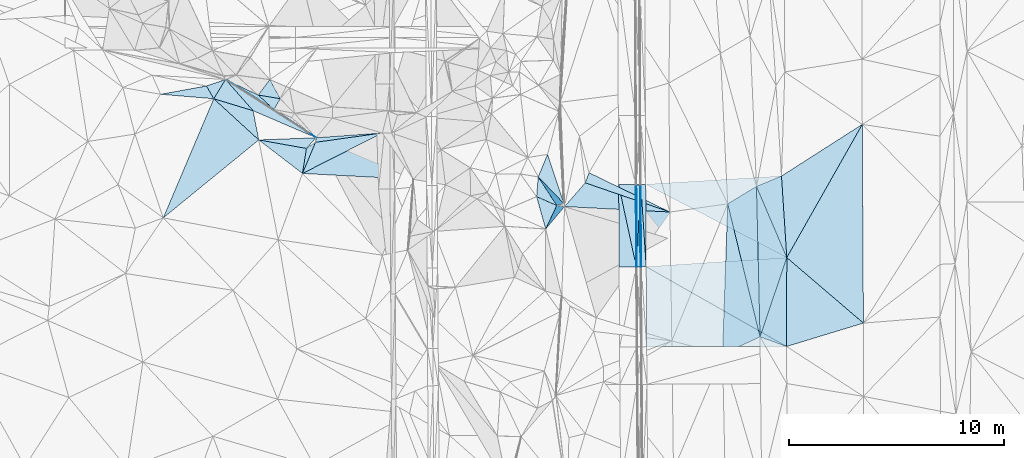
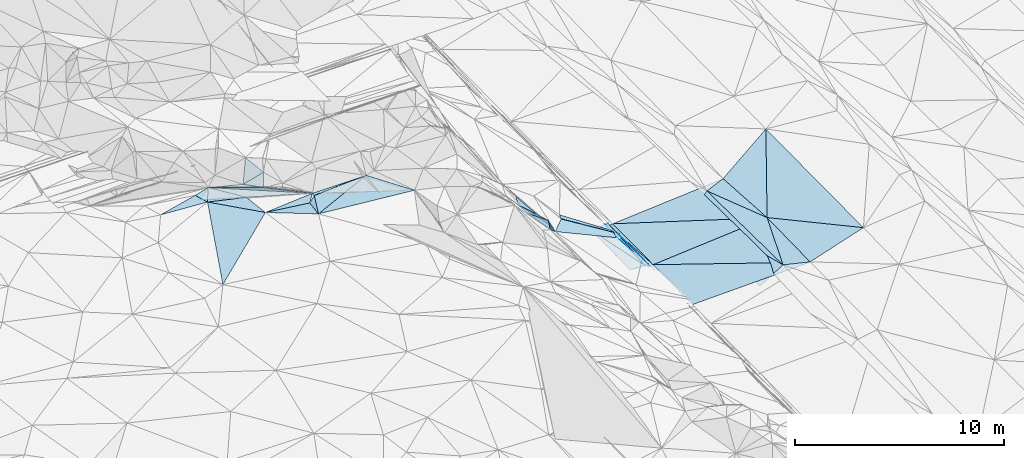
# One storey, part 56 of 275: 45 plates.
"""IFC2X3 building model written with IfcOpenShell, lengths in millimetres."""

from ifc_helpers import new_model, si_unit, frame, origin_with_axes, place, context, subcontext, project, spatial, polyline, outline, extrude, material, type_object, element, save


model = new_model("IFC2X3")

# Units and contexts
model_context = context("Model", 3, precision=1e-05, world=origin_with_axes())
body_context = subcontext(model_context, "Body", "Model", "MODEL_VIEW")
ifc_project = project(units=[si_unit("LENGTHUNIT", "METRE", prefix="MILLI"), si_unit("AREAUNIT", "SQUARE_METRE"), si_unit("VOLUMEUNIT", "CUBIC_METRE"), si_unit("MASSUNIT", "GRAM", prefix="KILO"), si_unit("TIMEUNIT", "SECOND"), si_unit("PLANEANGLEUNIT", "RADIAN"), si_unit("SOLIDANGLEUNIT", "STERADIAN"), si_unit("THERMODYNAMICTEMPERATUREUNIT", "DEGREE_CELSIUS"), si_unit("LUMINOUSINTENSITYUNIT", "LUMEN")], contexts=[model_context])

# Site, building, storey
site_placement = place(None, origin_with_axes())
site = spatial("IfcSite", under=ifc_project, at=site_placement, CompositionType="ELEMENT")
building_placement = place(site_placement, origin_with_axes())
building = spatial("IfcBuilding", under=site, at=building_placement, Name="Undefined", CompositionType="ELEMENT")
storey_placement = place(building_placement, origin_with_axes())
storey = spatial("IfcBuildingStorey", under=building, at=storey_placement, Name="Undefined", CompositionType="ELEMENT", Elevation=0.0)

# Plates
ifc_material = material()
plate_type_1 = type_object("IfcPlateType", PredefinedType="NOTDEFINED")
plate_1_placement = place(storey_placement, frame((-94049.4691106882, 47124.3842748434, 42016.0087509356), z_axis=(-0.970150804761025, -0.000843614877214956, -0.242500936772365), x_axis=(-0.00564236911128292, 0.999801756931878, 0.0190947769492665)))
element("IfcPlate", 1, at=plate_1_placement, inside=storey, type_object=plate_type_1, material=ifc_material, Name="00_PR", context=body_context, shape_type="SweptSolid", body=[
    extrude(outline(polyline([(0.0, 0.0), (3822.14477539063, -4.42378222942352e-09), (-1.945427775383, 123.677734375), (0.0, 0.0)])), frame((-8.85201319254618e-08, 2.18876761149539e-07, -0.5000001331573), z_axis=(0.0, 0.0, 1.0), x_axis=(1.0, 0.0, 0.0)), (0.0, 0.0, 1.0), 1.0),
])
plate_2_placement = place(storey_placement, frame((-94071.0352614292, 50945.7712675142, 42088.9925319801), z_axis=(-0.970540368074091, -0.000927874544757817, -0.240936782138878), x_axis=(0.240846376074367, 0.0239246409937553, -0.970268331280149)))
element("IfcPlate", 2, at=plate_2_placement, inside=storey, type_object=plate_type_1, material=ifc_material, Name="00_PR", context=body_context, shape_type="SweptSolid", body=[
    extrude(outline(polyline([(0.0, 0.0), (123.677124023438, -3.20142135024071e-10), (108.250579833984, 3824.55786132813), (0.0, 0.0)])), frame((-8.85201319254618e-08, 2.18876761149539e-07, -0.5000001331573), z_axis=(0.0, 0.0, 1.0), x_axis=(1.0, 0.0, 0.0)), (0.0, 0.0, 1.0), 1.0),
])
plate_type_2 = type_object("IfcPlateType", PredefinedType="NOTDEFINED")
plate_3_placement = place(storey_placement, frame((-94248.9903613323, 47123.2021820058, 42016.2301910769), z_axis=(-0.0201054512316629, 0.0189772573786107, -0.999617744206833), x_axis=(0.00220621589437379, 0.999818250675828, 0.0189366899682804)))
element("IfcPlate", 3, at=plate_3_placement, inside=storey, type_object=plate_type_2, material=ifc_material, Name="00_PR", context=body_context, shape_type="SweptSolid", body=[
    extrude(outline(polyline([(0.0, 0.0), (3822.3681640625, 5.355104804039e-09), (0.233179047703743, 30.0052471160889), (0.0, 0.0)])), frame((-8.85201319254618e-08, 2.18876761149539e-07, -0.5000001331573), z_axis=(0.0, 0.0, 1.0), x_axis=(1.0, 0.0, 0.0)), (0.0, 0.0, 1.0), 1.0),
])
plate_4_placement = place(storey_placement, frame((-94240.557385882, 50944.8755416985, 42088.6131918384), z_axis=(-0.0200937306992906, 0.0189772347856129, -0.999617980303714), x_axis=(-0.00220621588740689, -0.999818250676177, -0.0189366899506442)))
element("IfcPlate", 4, at=plate_4_placement, inside=storey, type_object=plate_type_2, material=ifc_material, Name="00_PR", context=body_context, shape_type="SweptSolid", body=[
    extrude(outline(polyline([(0.0, 0.0), (3822.3681640625, 5.355104804039e-09), (0.214805215597153, 30.0057525634766), (0.0, 0.0)])), frame((-8.85201319254618e-08, 2.18876761149539e-07, -0.5000001331573), z_axis=(0.0, 0.0, 1.0), x_axis=(1.0, 0.0, 0.0)), (0.0, 0.0, 1.0), 1.0),
])
plate_type_3 = type_object("IfcPlateType", PredefinedType="NOTDEFINED")
plate_5_placement = place(storey_placement, frame((-94248.9903613323, 47123.2021820058, 42016.2301910769), z_axis=(-0.0201058379220584, 0.0189746238774516, -0.999617786421471), x_axis=(-0.99978229263716, -0.00596045911850218, 0.0199960060082088)))
element("IfcPlate", 5, at=plate_5_placement, inside=storey, type_object=plate_type_3, material=ifc_material, Name="00_PR", context=body_context, shape_type="SweptSolid", body=[
    extrude(outline(polyline([(0.0, 0.0), (800.159790039063, 5.60248736292124e-09), (800.403381347656, 3822.779296875), (0.0, 0.0)])), frame((-8.85201319254618e-08, 2.18876761149539e-07, -0.5000001331573), z_axis=(0.0, 0.0, 1.0), x_axis=(1.0, 0.0, 0.0)), (0.0, 0.0, 1.0), 1.0),
])
plate_6_placement = place(storey_placement, frame((-95070.5458396395, 50940.4544931018, 42105.2131907828), z_axis=(-0.0200937306992906, 0.0189772347856129, -0.999617980303714), x_axis=(0.999785877876545, 0.0053252250960376, -0.0199960090093601)))
element("IfcPlate", 6, at=plate_6_placement, inside=storey, type_object=plate_type_3, material=ifc_material, Name="00_PR", context=body_context, shape_type="SweptSolid", body=[
    extrude(outline(polyline([(0.0, 0.0), (800.15966796875, 1.0113581083715e-09), (802.831176757813, 3822.27001953125), (0.0, 0.0)])), frame((-8.85201319254618e-08, 2.18876761149539e-07, -0.5000001331573), z_axis=(0.0, 0.0, 1.0), x_axis=(1.0, 0.0, 0.0)), (0.0, 0.0, 1.0), 1.0),
])
plate_type_4 = type_object("IfcPlateType", PredefinedType="NOTDEFINED")
plate_7_placement = place(storey_placement, frame((-94040.7465511964, 50948.7402933009, 41968.613357986), z_axis=(0.032498795467164, 0.0192577897591659, -0.999286228178281), x_axis=(0.0657092031432121, -0.997692452506924, -0.017090079958929)))
element("IfcPlate", 7, at=plate_7_placement, inside=storey, type_object=plate_type_4, material=ifc_material, Name="00_PR", context=body_context, shape_type="SweptSolid", body=[
    extrude(outline(polyline([(0.0, 0.0), (3831.63793945313, -3.01224645227194e-09), (3817.68505859375, 229.701293945313), (0.0, 0.0)])), frame((-8.85201319254618e-08, 2.18876761149539e-07, -0.5000001331573), z_axis=(0.0, 0.0, 1.0), x_axis=(1.0, 0.0, 0.0)), (0.0, 0.0, 1.0), 1.0),
])
plate_8_placement = place(storey_placement, frame((-94040.7469434197, 50948.7402655422, 41968.6133447093), z_axis=(0.0317146564647974, 0.0192065938860988, -0.999312407266424), x_axis=(0.998439383511723, 0.0453729910903855, 0.0325590100009581)))
element("IfcPlate", 8, at=plate_8_placement, inside=storey, type_object=plate_type_4, material=ifc_material, Name="00_PR", context=body_context, shape_type="SweptSolid", body=[
    extrude(outline(polyline([(0.0, 0.0), (230.504547119141, -9.45874489843845e-10), (75.7971954345703, 3830.88818359375), (0.0, 0.0)])), frame((-8.85201319254618e-08, 2.18876761149539e-07, -0.5000001331573), z_axis=(0.0, 0.0, 1.0), x_axis=(1.0, 0.0, 0.0)), (0.0, 0.0, 1.0), 1.0),
])
plate_type_5 = type_object("IfcPlateType", PredefinedType="NOTDEFINED")
plate_9_placement = place(storey_placement, frame((-98813.8662279933, 51306.4371091306, 44619.7632845197), z_axis=(-0.796210365658024, -0.376725235412677, -0.473420690952539), x_axis=(0.596366558088793, -0.620550605791343, -0.509179608827105)))
element("IfcPlate", 9, at=plate_9_placement, inside=storey, type_object=plate_type_5, material=ifc_material, Name="00", context=body_context, shape_type="SweptSolid", body=[
    extrude(outline(polyline([(0.0, 0.0), (2003.22241210938, -5.07861841470003e-09), (1541.86572265625, 549.681762695313), (0.0, 0.0)])), frame((-8.85201319254618e-08, 2.18876761149539e-07, -0.5000001331573), z_axis=(0.0, 0.0, 1.0), x_axis=(1.0, 0.0, 0.0)), (0.0, 0.0, 1.0), 1.0),
])
plate_type_6 = type_object("IfcPlateType", PredefinedType="NOTDEFINED")
plate_10_placement = place(storey_placement, frame((-94070.550046915, 50945.7812789745, 42088.6130915249), z_axis=(-0.00011385145127799, 0.019094438500524, -0.999817678107462), x_axis=(0.00564236912621122, -0.999801756931813, -0.0190947769482348)))
element("IfcPlate", 10, at=plate_10_placement, inside=storey, type_object=plate_type_6, material=ifc_material, Name="00_PR", context=body_context, shape_type="SweptSolid", body=[
    extrude(outline(polyline([(0.0, 0.0), (3822.14477539063, -4.42378222942352e-09), (3822.19897460938, 169.999664306641), (0.0, 0.0)])), frame((-8.85201319254618e-08, 2.18876761149539e-07, -0.5000001331573), z_axis=(0.0, 0.0, 1.0), x_axis=(1.0, 0.0, 0.0)), (0.0, 0.0, 1.0), 1.0),
])
plate_11_placement = place(storey_placement, frame((-94218.980736597, 47123.3806295609, 42015.6300917683), z_axis=(-0.000101724851935278, 0.0190939669352112, -0.99981768842061), x_axis=(-0.00564236911128292, 0.999801756931878, 0.0190947769492665)))
element("IfcPlate", 11, at=plate_11_placement, inside=storey, type_object=plate_type_6, material=ifc_material, Name="00_PR", context=body_context, shape_type="SweptSolid", body=[
    extrude(outline(polyline([(0.0, 0.0), (3822.25268554688, -1.35623849928379e-08), (3822.19897460938, 169.999755859375), (0.0, 0.0)])), frame((-8.85201319254618e-08, 2.18876761149539e-07, -0.5000001331573), z_axis=(0.0, 0.0, 1.0), x_axis=(1.0, 0.0, 0.0)), (0.0, 0.0, 1.0), 1.0),
])
plate_type_7 = type_object("IfcPlateType", PredefinedType="NOTDEFINED")
plate_12_placement = place(storey_placement, frame((-87491.6404198955, 51343.7037610381, 42163.2043052389), z_axis=(0.0283562339703342, 0.0202607606559367, -0.999392528275383), x_axis=(0.0645135621093858, -0.997747239133415, -0.0183969319617568)))
element("IfcPlate", 12, at=plate_12_placement, inside=storey, type_object=plate_type_7, material=ifc_material, Name="00_PR", context=body_context, shape_type="SweptSolid", body=[
    extrude(outline(polyline([(0.0, 0.0), (3803.40576171875, 1.20489858090878e-08), (-20.5789337158203, 6333.38134765625), (0.0, 0.0)])), frame((-8.85201319254618e-08, 2.18876761149539e-07, -0.5000001331573), z_axis=(0.0, 0.0, 1.0), x_axis=(1.0, 0.0, 0.0)), (0.0, 0.0, 1.0), 1.0),
])
plate_type_8 = type_object("IfcPlateType", PredefinedType="NOTDEFINED")
plate_13_placement = place(storey_placement, frame((-87246.2694836148, 47548.8661966718, 42093.2332986369), z_axis=(0.027715106074778, 0.0204726739549851, -0.999406194955983), x_axis=(-0.0019628878972951, -0.999787209570796, -0.0205349129470802)))
element("IfcPlate", 13, at=plate_13_placement, inside=storey, type_object=plate_type_8, material=ifc_material, Name="00_PR", context=body_context, shape_type="SweptSolid", body=[
    extrude(outline(polyline([(0.0, 0.0), (4137.392578125, 6.63567334413528e-09), (439.577911376953, 6544.369140625), (0.0, 0.0)])), frame((-8.85201319254618e-08, 2.18876761149539e-07, -0.5000001331573), z_axis=(0.0, 0.0, 1.0), x_axis=(1.0, 0.0, 0.0)), (0.0, 0.0, 1.0), 1.0),
])
plate_type_9 = type_object("IfcPlateType", PredefinedType="NOTDEFINED")
plate_14_placement = place(storey_placement, frame((-93788.9750228899, 47125.9439782775, 41903.130286756), z_axis=(0.0277989038150563, 0.0191867273021548, -0.999429382418845), x_axis=(-0.00564136611685734, 0.999802864683773, 0.0190369839642749)))
element("IfcPlate", 14, at=plate_14_placement, inside=storey, type_object=plate_type_9, material=ifc_material, Name="00_PR", context=body_context, shape_type="SweptSolid", body=[
    extrude(outline(polyline([(0.0, 0.0), (3834.0107421875, 1.87719706445932e-09), (389.547393798828, 6547.53759765625), (0.0, 0.0)])), frame((-8.85201319254618e-08, 2.18876761149539e-07, -0.5000001331573), z_axis=(0.0, 0.0, 1.0), x_axis=(1.0, 0.0, 0.0)), (0.0, 0.0, 1.0), 1.0),
])
plate_type_10 = type_object("IfcPlateType", PredefinedType="NOTDEFINED")
plate_15_placement = place(storey_placement, frame((-93765.6495708748, 43406.0215007498, 41814.9273639222), z_axis=(0.029649190941769, 0.0238796797927893, -0.999275080430555), x_axis=(-0.00626827611745756, 0.999699373272636, 0.0237038349811692)))
element("IfcPlate", 15, at=plate_15_placement, inside=storey, type_object=plate_type_10, material=ifc_material, Name="00_PR", context=body_context, shape_type="SweptSolid", body=[
    extrude(outline(polyline([(0.0, 0.0), (3721.04345703125, -1.51339918375015e-09), (-29.8991641998291, 6514.064453125), (0.0, 0.0)])), frame((-8.85201319254618e-08, 2.18876761149539e-07, -0.5000001331573), z_axis=(0.0, 0.0, 1.0), x_axis=(1.0, 0.0, 0.0)), (0.0, 0.0, 1.0), 1.0),
])
plate_type_11 = type_object("IfcPlateType", PredefinedType="NOTDEFINED")
plate_16_placement = place(storey_placement, frame((-106064.043957052, 53350.4445405237, 47651.5007667485), z_axis=(-0.0551706347526953, 0.00929269626839723, -0.998433696775629), x_axis=(-0.890992843470738, -0.45177887148522, 0.0450289258529515)))
element("IfcPlate", 16, at=plate_16_placement, inside=storey, type_object=plate_type_11, material=ifc_material, Name="00", context=body_context, shape_type="SweptSolid", body=[
    extrude(outline(polyline([(0.0, 0.0), (4175.09423828125, 1.27911334857345e-08), (2979.78198242188, 1018.64086914063), (0.0, 0.0)])), frame((-8.85201319254618e-08, 2.18876761149539e-07, -0.5000001331573), z_axis=(0.0, 0.0, 1.0), x_axis=(1.0, 0.0, 0.0)), (0.0, 0.0, 1.0), 1.0),
])
plate_type_12 = type_object("IfcPlateType", PredefinedType="NOTDEFINED")
plate_17_placement = place(storey_placement, frame((-92681.4294832111, 49670.4916485451, 41369.5422176029), z_axis=(-0.386069611875739, 0.112895459450465, -0.915535291521624), x_axis=(-0.918291766371843, 0.0473165613790901, 0.393066628999383)))
element("IfcPlate", 17, at=plate_17_placement, inside=storey, type_object=plate_type_12, material=ifc_material, Name="00", context=body_context, shape_type="SweptSolid", body=[
    extrude(outline(polyline([(0.0, 0.0), (5345.14990234375, 4.15166141465306e-08), (4404.07958984375, 1158.07080078125), (0.0, 0.0)])), frame((-8.85201319254618e-08, 2.18876761149539e-07, -0.5000001331573), z_axis=(0.0, 0.0, 1.0), x_axis=(1.0, 0.0, 0.0)), (0.0, 0.0, 1.0), 1.0),
])
plate_type_13 = type_object("IfcPlateType", PredefinedType="NOTDEFINED")
plate_18_placement = place(storey_placement, frame((-97590.0720029308, 49923.4942873993, 43470.7872462764), z_axis=(-0.857233919691697, 0.290004723110266, -0.425496495289617), x_axis=(-0.508508532784934, -0.60683614989851, 0.610875567739672)))
element("IfcPlate", 18, at=plate_18_placement, inside=storey, type_object=plate_type_13, material=ifc_material, Name="00", context=body_context, shape_type="SweptSolid", body=[
    extrude(outline(polyline([(0.0, 0.0), (1717.20727539063, -4.70026861876249e-09), (617.509033203125, 571.807312011719), (0.0, 0.0)])), frame((-8.85201319254618e-08, 2.18876761149539e-07, -0.5000001331573), z_axis=(0.0, 0.0, 1.0), x_axis=(1.0, 0.0, 0.0)), (0.0, 0.0, 1.0), 1.0),
])
plate_type_14 = type_object("IfcPlateType", PredefinedType="NOTDEFINED")
plate_19_placement = place(storey_placement, frame((-88657.0998739507, 50861.2628079218, 42150.5000732969), z_axis=(0.00950168249015876, 0.0164224781360441, -0.999819993919769), x_axis=(0.923860505487271, 0.382432895473588, 0.0150614362028502)))
element("IfcPlate", 19, at=plate_19_placement, inside=storey, type_object=plate_type_14, material=ifc_material, Name="00", context=body_context, shape_type="SweptSolid", body=[
    extrude(outline(polyline([(0.0, 0.0), (1261.49987792969, 5.29689714312553e-09), (36.0142707824707, 3600.38671875), (0.0, 0.0)])), frame((-8.85201319254618e-08, 2.18876761149539e-07, -0.5000001331573), z_axis=(0.0, 0.0, 1.0), x_axis=(1.0, 0.0, 0.0)), (0.0, 0.0, 1.0), 1.0),
])
plate_type_15 = type_object("IfcPlateType", PredefinedType="NOTDEFINED")
plate_20_placement = place(storey_placement, frame((-97619.1247379874, 50063.5457374693, 43599.6094281757), z_axis=(-0.622930109313069, 0.0422892423594386, -0.781133598619258), x_axis=(-0.596366558093075, 0.620550605785872, 0.509179608828757)))
element("IfcPlate", 20, at=plate_20_placement, inside=storey, type_object=plate_type_15, material=ifc_material, Name="00", context=body_context, shape_type="SweptSolid", body=[
    extrude(outline(polyline([(0.0, 0.0), (2003.22241210938, -5.07861841470003e-09), (2244.8330078125, 1143.03295898438), (0.0, 0.0)])), frame((-8.85201319254618e-08, 2.18876761149539e-07, -0.5000001331573), z_axis=(0.0, 0.0, 1.0), x_axis=(1.0, 0.0, 0.0)), (0.0, 0.0, 1.0), 1.0),
])
plate_type_16 = type_object("IfcPlateType", PredefinedType="NOTDEFINED")
plate_21_placement = place(storey_placement, frame((-113912.671360646, 54941.8283813191, 47869.5033694293), z_axis=(0.0186082352914814, 0.114693590259117, -0.993226617611918), x_axis=(0.519151387178403, 0.84787758495937, 0.107635673055941)))
element("IfcPlate", 21, at=plate_21_placement, inside=storey, type_object=plate_type_16, material=ifc_material, Name="00", context=body_context, shape_type="SweptSolid", body=[
    extrude(outline(polyline([(0.0, 0.0), (1059.12841796875, -1.06228981167078e-09), (475.419219970703, 1854.6904296875), (0.0, 0.0)])), frame((-8.85201319254618e-08, 2.18876761149539e-07, -0.5000001331573), z_axis=(0.0, 0.0, 1.0), x_axis=(1.0, 0.0, 0.0)), (0.0, 0.0, 1.0), 1.0),
])
plate_type_17 = type_object("IfcPlateType", PredefinedType="NOTDEFINED")
plate_22_placement = place(storey_placement, frame((-111300.267116492, 55834.509346729, 49019.6536103259), z_axis=(0.402637561837239, 0.598313708758797, -0.692750820792771), x_axis=(0.427884643091365, -0.79205563174139, -0.435387882735983)))
element("IfcPlate", 22, at=plate_22_placement, inside=storey, type_object=plate_type_17, material=ifc_material, Name="00", context=body_context, shape_type="SweptSolid", body=[
    extrude(outline(polyline([(0.0, 0.0), (1125.43322753906, 4.36557456851006e-11), (747.978637695313, 1068.5634765625), (0.0, 0.0)])), frame((-8.85201319254618e-08, 2.18876761149539e-07, -0.5000001331573), z_axis=(0.0, 0.0, 1.0), x_axis=(1.0, 0.0, 0.0)), (0.0, 0.0, 1.0), 1.0),
])
plate_type_18 = type_object("IfcPlateType", PredefinedType="NOTDEFINED")
plate_23_placement = place(storey_placement, frame((-87246.2744948067, 47548.865974475, 42109.5001644752), z_axis=(0.0178730044978072, 0.0199857811533345, -0.999640497509936), x_axis=(-0.319712311414911, -0.947193878387781, -0.0246534921349707)))
element("IfcPlate", 23, at=plate_23_placement, inside=storey, type_object=plate_type_18, material=ifc_material, Name="00", context=body_context, shape_type="SweptSolid", body=[
    extrude(outline(polyline([(0.0, 0.0), (3893.9716796875, -4.62750904262066e-09), (-2687.4375, 2396.197265625), (0.0, 0.0)])), frame((-8.85201319254618e-08, 2.18876761149539e-07, -0.5000001331573), z_axis=(0.0, 0.0, 1.0), x_axis=(1.0, 0.0, 0.0)), (0.0, 0.0, 1.0), 1.0),
])
plate_type_19 = type_object("IfcPlateType", PredefinedType="NOTDEFINED")
plate_24_placement = place(storey_placement, frame((-109154.719060787, 53125.8200691528, 47820.8561841646), z_axis=(0.511278252398943, 0.809863094038306, -0.287604446312265), x_axis=(-0.83988634228573, 0.541786326990976, 0.032534718801993)))
element("IfcPlate", 24, at=plate_24_placement, inside=storey, type_object=plate_type_19, material=ifc_material, Name="00", context=body_context, shape_type="SweptSolid", body=[
    extrude(outline(polyline([(0.0, 0.0), (5010.03271484375, -3.13812051899731e-08), (2363.73999023438, 158.897766113281), (0.0, 0.0)])), frame((-8.85201319254618e-08, 2.18876761149539e-07, -0.5000001331573), z_axis=(0.0, 0.0, 1.0), x_axis=(1.0, 0.0, 0.0)), (0.0, 0.0, 1.0), 1.0),
])
plate_type_20 = type_object("IfcPlateType", PredefinedType="NOTDEFINED")
plate_25_placement = place(storey_placement, frame((-113362.803943288, 55839.8564239458, 47983.5063338839), z_axis=(0.0574137023576031, 0.148290429147165, -0.987275855779398), x_axis=(0.839886342553011, -0.541786326574174, -0.03253471884293)))
element("IfcPlate", 25, at=plate_25_placement, inside=storey, type_object=plate_type_20, material=ifc_material, Name="00", context=body_context, shape_type="SweptSolid", body=[
    extrude(outline(polyline([(0.0, 0.0), (5010.03271484375, -3.13812051899731e-08), (1869.50317382813, 534.369445800781), (0.0, 0.0)])), frame((-8.85201319254618e-08, 2.18876761149539e-07, -0.5000001331573), z_axis=(0.0, 0.0, 1.0), x_axis=(1.0, 0.0, 0.0)), (0.0, 0.0, 1.0), 1.0),
])
plate_type_21 = type_object("IfcPlateType", PredefinedType="NOTDEFINED")
plate_26_placement = place(storey_placement, frame((-113362.747268402, 55839.8970783269, 47983.5208871229), z_axis=(0.170667743658946, 0.229632350388664, -0.958197007368183), x_axis=(0.900310439939153, -0.431506897790421, 0.0569465441959014)))
element("IfcPlate", 26, at=plate_26_placement, inside=storey, type_object=plate_type_21, material=ifc_material, Name="00", context=body_context, shape_type="SweptSolid", body=[
    extrude(outline(polyline([(0.0, 0.0), (1685.79150390625, 8.41464498080313e-09), (2634.07592773438, 299.593811035156), (0.0, 0.0)])), frame((-8.85201319254618e-08, 2.18876761149539e-07, -0.5000001331573), z_axis=(0.0, 0.0, 1.0), x_axis=(1.0, 0.0, 0.0)), (0.0, 0.0, 1.0), 1.0),
])
plate_type_22 = type_object("IfcPlateType", PredefinedType="NOTDEFINED")
plate_27_placement = place(storey_placement, frame((-113912.732568988, 54941.8648068625, 47869.5116033027), z_axis=(-0.103787346591686, 0.187545098923361, -0.976757402100073), x_axis=(-0.48435049468112, 0.848214289739435, 0.214329458973751)))
element("IfcPlate", 27, at=plate_27_placement, inside=storey, type_object=plate_type_22, material=ifc_material, Name="00", context=body_context, shape_type="SweptSolid", body=[
    extrude(outline(polyline([(0.0, 0.0), (699.857116699219, -1.74622982740402e-09), (519.820373535156, 922.789123535156), (0.0, 0.0)])), frame((-8.85201319254618e-08, 2.18876761149539e-07, -0.5000001331573), z_axis=(0.0, 0.0, 1.0), x_axis=(1.0, 0.0, 0.0)), (0.0, 0.0, 1.0), 1.0),
])
plate_type_23 = type_object("IfcPlateType", PredefinedType="NOTDEFINED")
plate_28_placement = place(storey_placement, frame((-111111.093026822, 54442.0416425444, 48049.6172239658), z_axis=(0.416694572199318, 0.490242148668029, -0.765524832496622), x_axis=(-0.737865015454161, 0.674273838183951, 0.0301663738210954)))
element("IfcPlate", 28, at=plate_28_placement, inside=storey, type_object=plate_type_23, material=ifc_material, Name="00", context=body_context, shape_type="SweptSolid", body=[
    extrude(outline(polyline([(0.0, 0.0), (994.484802246094, -3.3796823117882e-09), (136.553115844727, 740.441223144531), (0.0, 0.0)])), frame((-8.85201319254618e-08, 2.18876761149539e-07, -0.5000001331573), z_axis=(0.0, 0.0, 1.0), x_axis=(1.0, 0.0, 0.0)), (0.0, 0.0, 1.0), 1.0),
])
plate_type_24 = type_object("IfcPlateType", PredefinedType="NOTDEFINED")
plate_29_placement = place(storey_placement, frame((-109598.926103981, 52628.5528323706, 47709.5087981391), z_axis=(0.0414164561561285, 0.182417328189519, -0.982348510222144), x_axis=(-0.984397163380895, 0.175737191386963, -0.00886928920884901)))
element("IfcPlate", 29, at=plate_29_placement, inside=storey, type_object=plate_type_24, material=ifc_material, Name="00", context=body_context, shape_type="SweptSolid", body=[
    extrude(outline(polyline([(0.0, 0.0), (2254.97216796875, -1.39771145768464e-08), (-350.696105957031, 577.414245605469), (0.0, 0.0)])), frame((-8.85201319254618e-08, 2.18876761149539e-07, -0.5000001331573), z_axis=(0.0, 0.0, 1.0), x_axis=(1.0, 0.0, 0.0)), (0.0, 0.0, 1.0), 1.0),
])
plate_type_25 = type_object("IfcPlateType", PredefinedType="NOTDEFINED")
plate_30_placement = place(storey_placement, frame((-89994.750347839, 50051.1990169945, 41923.5017007742), z_axis=(0.0825151041257743, 0.0055526173580561, -0.996574345461285), x_axis=(0.235989350566509, -0.971652966097508, 0.0141258590220819)))
element("IfcPlate", 30, at=plate_30_placement, inside=storey, type_object=plate_type_25, material=ifc_material, Name="00", context=body_context, shape_type="SweptSolid", body=[
    extrude(outline(polyline([(0.0, 0.0), (6371.2939453125, 6.72298483550549e-09), (6739.97509765625, 1892.43762207031), (0.0, 0.0)])), frame((-8.85201319254618e-08, 2.18876761149539e-07, -0.5000001331573), z_axis=(0.0, 0.0, 1.0), x_axis=(1.0, 0.0, 0.0)), (0.0, 0.0, 1.0), 1.0),
])
plate_type_26 = type_object("IfcPlateType", PredefinedType="NOTDEFINED")
plate_31_placement = place(storey_placement, frame((-97950.2376504927, 49971.7501612915, 44229.5626716291), z_axis=(-0.48152454680683, -0.0559395979426796, -0.874645569476281), x_axis=(-0.8249833875903, 0.36582105103439, 0.430786918116286)))
element("IfcPlate", 31, at=plate_31_placement, inside=storey, type_object=plate_type_26, material=ifc_material, Name="00", context=body_context, shape_type="SweptSolid", body=[
    extrude(outline(polyline([(0.0, 0.0), (1137.45324707031, -6.91034074407071e-09), (1368.67163085938, 897.907653808594), (0.0, 0.0)])), frame((-8.85201319254618e-08, 2.18876761149539e-07, -0.5000001331573), z_axis=(0.0, 0.0, 1.0), x_axis=(1.0, 0.0, 0.0)), (0.0, 0.0, 1.0), 1.0),
])
plate_type_27 = type_object("IfcPlateType", PredefinedType="NOTDEFINED")
plate_32_placement = place(storey_placement, frame((-98463.0919620187, 48881.2783618372, 44519.5581918865), z_axis=(-0.467996611778252, -0.0148815264005445, -0.883604952190777), x_axis=(-0.269612987207424, 0.954594355881511, 0.126721950932944)))
element("IfcPlate", 32, at=plate_32_placement, inside=storey, type_object=plate_type_27, material=ifc_material, Name="00", context=body_context, shape_type="SweptSolid", body=[
    extrude(outline(polyline([(0.0, 0.0), (1578.25854492188, 6.86850398778915e-09), (865.954467773438, 886.804870605469), (0.0, 0.0)])), frame((-8.85201319254618e-08, 2.18876761149539e-07, -0.5000001331573), z_axis=(0.0, 0.0, 1.0), x_axis=(1.0, 0.0, 0.0)), (0.0, 0.0, 1.0), 1.0),
])
plate_type_28 = type_object("IfcPlateType", PredefinedType="NOTDEFINED")
plate_33_placement = place(storey_placement, frame((-88657.0277596138, 50861.2660770149, 42150.5060648278), z_axis=(0.153721512970564, 0.0229736864643383, -0.987847106682142), x_axis=(0.0236820835390731, -0.999528169136668, -0.0195601130249761)))
element("IfcPlate", 33, at=plate_33_placement, inside=storey, type_object=plate_type_28, material=ifc_material, Name="00", context=body_context, shape_type="SweptSolid", body=[
    extrude(outline(polyline([(0.0, 0.0), (7004.04931640625, -2.25409166887403e-08), (782.437072753906, 1372.92468261719), (0.0, 0.0)])), frame((-8.85201319254618e-08, 2.18876761149539e-07, -0.5000001331573), z_axis=(0.0, 0.0, 1.0), x_axis=(1.0, 0.0, 0.0)), (0.0, 0.0, 1.0), 1.0),
])
plate_type_29 = type_object("IfcPlateType", PredefinedType="NOTDEFINED")
plate_34_placement = place(storey_placement, frame((-113912.671613258, 54941.8275614064, 47869.5032708588), z_axis=(0.0181070519031837, 0.113056018102655, -0.993423611276754), x_axis=(0.956627078167207, -0.290893670348447, -0.0156686268856569)))
element("IfcPlate", 34, at=plate_34_placement, inside=storey, type_object=plate_type_29, material=ifc_material, Name="00", context=body_context, shape_type="SweptSolid", body=[
    extrude(outline(polyline([(0.0, 0.0), (1914.65405273438, 1.12995621748269e-08), (2563.59643554688, 1232.87219238281), (0.0, 0.0)])), frame((-8.85201319254618e-08, 2.18876761149539e-07, -0.5000001331573), z_axis=(0.0, 0.0, 1.0), x_axis=(1.0, 0.0, 0.0)), (0.0, 0.0, 1.0), 1.0),
])
plate_type_30 = type_object("IfcPlateType", PredefinedType="NOTDEFINED")
plate_35_placement = place(storey_placement, frame((-109177.859894812, 52912.8687882567, 47819.5380972057), z_axis=(0.348578550896836, -0.158553265404507, -0.923771538793131), x_axis=(-0.385845086325422, -0.922475685137798, 0.0127349789194056)))
element("IfcPlate", 35, at=plate_35_placement, inside=storey, type_object=plate_type_30, material=ifc_material, Name="00", context=body_context, shape_type="SweptSolid", body=[
    extrude(outline(polyline([(0.0, 0.0), (1570.47766113281, 2.82307155430317e-09), (423.438049316406, 301.496612548828), (0.0, 0.0)])), frame((-8.85201319254618e-08, 2.18876761149539e-07, -0.5000001331573), z_axis=(0.0, 0.0, 1.0), x_axis=(1.0, 0.0, 0.0)), (0.0, 0.0, 1.0), 1.0),
])
plate_type_31 = type_object("IfcPlateType", PredefinedType="NOTDEFINED")
plate_36_placement = place(storey_placement, frame((-92681.4514318657, 49670.419068559, 41369.54883651), z_axis=(-0.429912230238184, -0.0322629995535372, -0.902294061352195), x_axis=(-0.86579938193704, 0.298157396381107, 0.401862659649637)))
element("IfcPlate", 36, at=plate_36_placement, inside=storey, type_object=plate_type_31, material=ifc_material, Name="00", context=body_context, shape_type="SweptSolid", body=[
    extrude(outline(polyline([(0.0, 0.0), (4553.79443359375, 2.67791619990021e-08), (4502.85009765625, 509.416015625), (0.0, 0.0)])), frame((-8.85201319254618e-08, 2.18876761149539e-07, -0.5000001331573), z_axis=(0.0, 0.0, 1.0), x_axis=(1.0, 0.0, 0.0)), (0.0, 0.0, 1.0), 1.0),
])
plate_type_32 = type_object("IfcPlateType", PredefinedType="NOTDEFINED")
plate_37_placement = place(storey_placement, frame((-109155.002460666, 53125.4205091141, 47820.5007788618), z_axis=(-0.0553681617616374, 0.0107083179490908, -0.998408582990871), x_axis=(0.995880890734849, 0.0725010846563428, -0.0544503828528022)))
element("IfcPlate", 37, at=plate_37_placement, inside=storey, type_object=plate_type_32, material=ifc_material, Name="00", context=body_context, shape_type="SweptSolid", body=[
    extrude(outline(polyline([(0.0, 0.0), (3103.7431640625, -1.01717887446284e-08), (-38.3140602111816, 210.254684448242), (0.0, 0.0)])), frame((-8.85201319254618e-08, 2.18876761149539e-07, -0.5000001331573), z_axis=(0.0, 0.0, 1.0), x_axis=(1.0, 0.0, 0.0)), (0.0, 0.0, 1.0), 1.0),
])
plate_type_33 = type_object("IfcPlateType", PredefinedType="NOTDEFINED")
plate_38_placement = place(storey_placement, frame((-114251.644024414, 55535.5291405777, 48019.5171442218), z_axis=(0.0255188439895642, 0.258576287875061, -0.965653712233423), x_axis=(0.484350494642086, -0.848214289771247, -0.214329458936064)))
element("IfcPlate", 38, at=plate_38_placement, inside=storey, type_object=plate_type_33, material=ifc_material, Name="00", context=body_context, shape_type="SweptSolid", body=[
    extrude(outline(polyline([(0.0, 0.0), (699.857116699219, -1.74622982740402e-09), (-672.280090332031, 2070.22680664063), (0.0, 0.0)])), frame((-8.85201319254618e-08, 2.18876761149539e-07, -0.5000001331573), z_axis=(0.0, 0.0, 1.0), x_axis=(1.0, 0.0, 0.0)), (0.0, 0.0, 1.0), 1.0),
])
plate_type_34 = type_object("IfcPlateType", PredefinedType="NOTDEFINED")
plate_39_placement = place(storey_placement, frame((-109784.000513033, 51464.1659802303, 47839.5029962515), z_axis=(-0.0105584362097484, -0.109307206239275, -0.993951937514571), x_axis=(-0.792147464224852, 0.607529603338832, -0.0583967121428741)))
element("IfcPlate", 39, at=plate_39_placement, inside=storey, type_object=plate_type_34, material=ifc_material, Name="00", context=body_context, shape_type="SweptSolid", body=[
    extrude(outline(polyline([(0.0, 0.0), (2568.6376953125, 2.51020537689328e-10), (568.316772460938, 1040.96875), (0.0, 0.0)])), frame((-8.85201319254618e-08, 2.18876761149539e-07, -0.5000001331573), z_axis=(0.0, 0.0, 1.0), x_axis=(1.0, 0.0, 0.0)), (0.0, 0.0, 1.0), 1.0),
])
plate_type_35 = type_object("IfcPlateType", PredefinedType="NOTDEFINED")
plate_40_placement = place(storey_placement, frame((-113912.673580025, 54941.8254033303, 47869.5029947738), z_axis=(0.0141352334976891, 0.108768632145634, -0.993966588892772), x_axis=(0.736101053555023, -0.673907474661832, -0.0632768089437018)))
element("IfcPlate", 40, at=plate_40_placement, inside=storey, type_object=plate_type_35, material=ifc_material, Name="00", context=body_context, shape_type="SweptSolid", body=[
    extrude(outline(polyline([(0.0, 0.0), (2844.64404296875, 5.56246959604323e-09), (2046.86413574219, 5697.93359375), (0.0, 0.0)])), frame((-8.85201319254618e-08, 2.18876761149539e-07, -0.5000001331573), z_axis=(0.0, 0.0, 1.0), x_axis=(1.0, 0.0, 0.0)), (0.0, 0.0, 1.0), 1.0),
])
plate_type_36 = type_object("IfcPlateType", PredefinedType="NOTDEFINED")
plate_41_placement = place(storey_placement, frame((-87254.394699548, 43412.3533205159, 42029.5001771794), z_axis=(0.0199223088779908, 0.0192934122807716, -0.999615358951399), x_axis=(-0.940111482334408, 0.340650109484019, -0.0121615661626082)))
element("IfcPlate", 41, at=plate_41_placement, inside=storey, type_object=plate_type_36, material=ifc_material, Name="00", context=body_context, shape_type="SweptSolid", body=[
    extrude(outline(polyline([(0.0, 0.0), (1315.61999511719, 9.36597643885762e-09), (1400.49560546875, 3893.04663085938), (0.0, 0.0)])), frame((-8.85201319254618e-08, 2.18876761149539e-07, -0.5000001331573), z_axis=(0.0, 0.0, 1.0), x_axis=(1.0, 0.0, 0.0)), (0.0, 0.0, 1.0), 1.0),
])
plate_type_37 = type_object("IfcPlateType", PredefinedType="NOTDEFINED")
plate_42_placement = place(storey_placement, frame((-87246.2737862351, 47548.8656290863, 42109.500170952), z_axis=(0.0192896125450526, 0.0192948930699912, -0.999627739685769), x_axis=(0.760252354456763, -0.649624364504467, 0.00213133411626815)))
element("IfcPlate", 42, at=plate_42_placement, inside=storey, type_object=plate_type_37, material=ifc_material, Name="00", context=body_context, shape_type="SweptSolid", body=[
    extrude(outline(polyline([(0.0, 0.0), (4691.8974609375, -9.45874489843845e-10), (2680.83447265625, 3151.24194335938), (0.0, 0.0)])), frame((-8.85201319254618e-08, 2.18876761149539e-07, -0.5000001331573), z_axis=(0.0, 0.0, 1.0), x_axis=(1.0, 0.0, 0.0)), (0.0, 0.0, 1.0), 1.0),
])
plate_type_38 = type_object("IfcPlateType", PredefinedType="NOTDEFINED")
plate_43_placement = place(storey_placement, frame((-83733.1809985526, 53748.7915696868, 42299.5001759808), z_axis=(0.0195249288577178, 0.0195703153425327, -0.999617816923295), x_axis=(0.00583074664313745, -0.999793636651844, -0.0194598690659714)))
element("IfcPlate", 43, at=plate_43_placement, inside=storey, type_object=plate_type_38, material=ifc_material, Name="00", context=body_context, shape_type="SweptSolid", body=[
    extrude(outline(polyline([(0.0, 0.0), (9249.8056640625, 1.17870513349772e-09), (6181.85986328125, 3549.87451171875), (0.0, 0.0)])), frame((-8.85201319254618e-08, 2.18876761149539e-07, -0.5000001331573), z_axis=(0.0, 0.0, 1.0), x_axis=(1.0, 0.0, 0.0)), (0.0, 0.0, 1.0), 1.0),
])
plate_type_39 = type_object("IfcPlateType", PredefinedType="NOTDEFINED")
plate_44_placement = place(storey_placement, frame((-87246.2716823737, 47548.8646401603, 42109.5001977571), z_axis=(0.0234886747407399, 0.0173229768084682, -0.999574007581938), x_axis=(-0.0645164526074498, 0.997791934158675, 0.0157760410382539)))
element("IfcPlate", 44, at=plate_44_placement, inside=storey, type_object=plate_type_39, material=ifc_material, Name="00", context=body_context, shape_type="SweptSolid", body=[
    extrude(outline(polyline([(0.0, 0.0), (3803.2353515625, -3.79804987460375e-09), (5962.5810546875, 3906.9970703125), (0.0, 0.0)])), frame((-8.85201319254618e-08, 2.18876761149539e-07, -0.5000001331573), z_axis=(0.0, 0.0, 1.0), x_axis=(1.0, 0.0, 0.0)), (0.0, 0.0, 1.0), 1.0),
])
plate_type_40 = type_object("IfcPlateType", PredefinedType="NOTDEFINED")
plate_45_placement = place(storey_placement, frame((-106064.041562113, 53350.4397471732, 47651.5006150918), z_axis=(-0.0503290284166933, -0.000285657986365758, -0.998732650561774), x_axis=(0.55538189356271, -0.831132307828336, -0.0277495799363201)))
element("IfcPlate", 45, at=plate_45_placement, inside=storey, type_object=plate_type_40, material=ifc_material, Name="00", context=body_context, shape_type="SweptSolid", body=[
    extrude(outline(polyline([(0.0, 0.0), (2594.6337890625, -6.86122803017497e-09), (-503.528076171875, 4144.619140625), (0.0, 0.0)])), frame((-8.85201319254618e-08, 2.18876761149539e-07, -0.5000001331573), z_axis=(0.0, 0.0, 1.0), x_axis=(1.0, 0.0, 0.0)), (0.0, 0.0, 1.0), 1.0),
])

save(model, "model.ifc")
